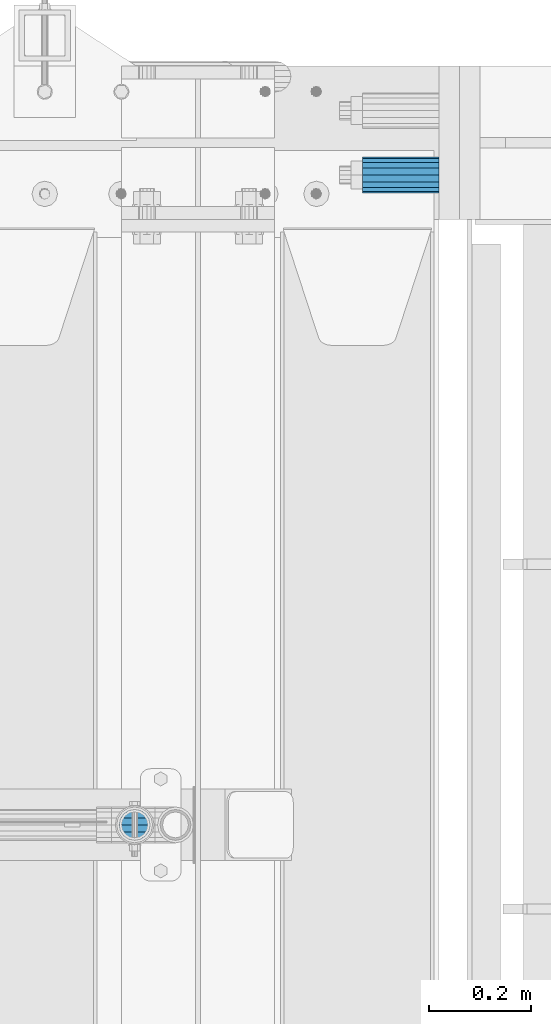
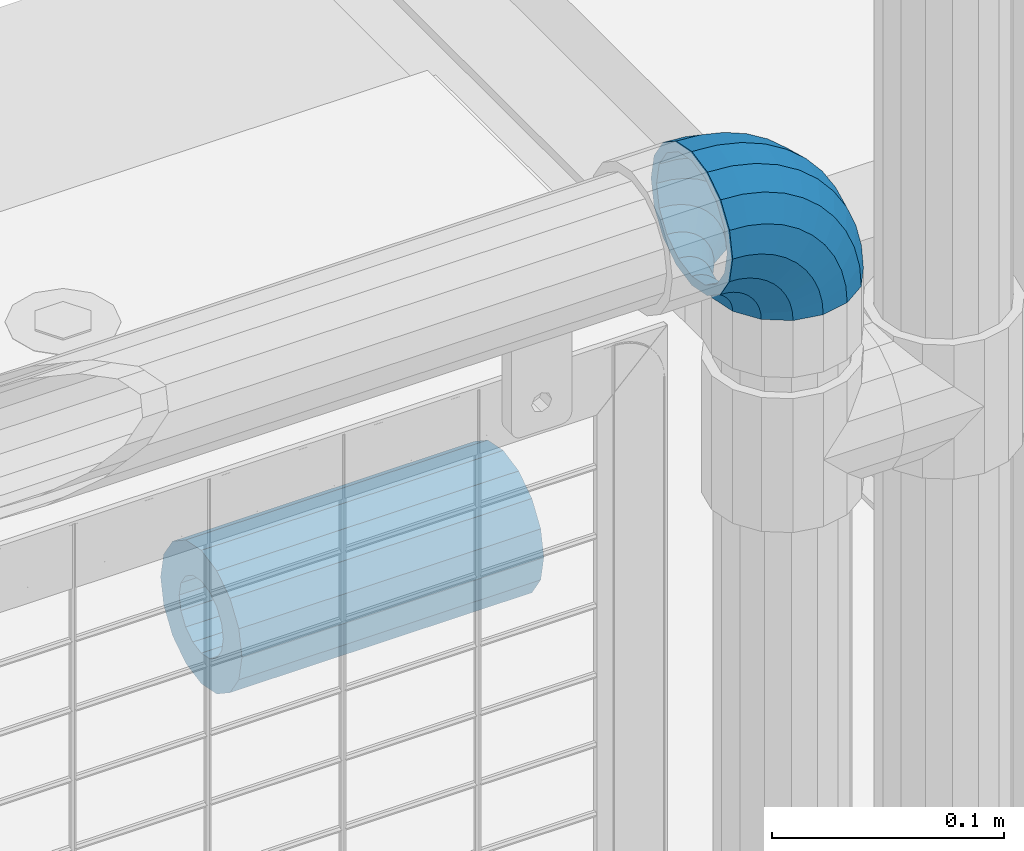
# One storey, part 170 of 242: 1 beam, 1 member.
"""IFC2X3 building model written with IfcOpenShell, lengths in millimetres."""

import ifcopenshell
import ifcopenshell.guid

model = None  # the IFC model being written
_history = None  # IfcOwnerHistory: only IFC2X3 demands one
_inside = {}  # id of a spatial element -> (the spatial element, [elements in it])
_under = {}  # id of a project, library or spatial element -> (it, [spatial elements below it])
_declared = {}  # id of a project -> (the project, [libraries it declares])
_typed = {}  # id of a type object -> (the type object, [elements of that type])
_made_of = {}  # id of a material, layer set ... -> (it, [elements and type objects made of it])


def new_model(schema):
    """Start an empty IFC model of exactly this schema.

    Asked for "IFC4X3", IfcOpenShell would pick the latest addendum, in which some entities
    have other attributes; the version numbers below select the first issue.
    IFC2X3 requires an IfcOwnerHistory on every rooted entity: one is made here for all.
    """
    global model, _history
    if schema == "IFC4X3":
        model = ifcopenshell.file(schema_version=(4, 3, 0, 0))
    else:
        model = ifcopenshell.file(schema=schema)
    _inside.clear()
    _under.clear()
    _declared.clear()
    _typed.clear()
    _made_of.clear()
    _history = None
    if model.schema == "IFC2X3":
        org = make("IfcOrganization", Name="unknown")
        user = make(
            "IfcPersonAndOrganization",
            ThePerson=make("IfcPerson", FamilyName="unknown"),
            TheOrganization=org,
        )
        app = make(
            "IfcApplication",
            ApplicationDeveloper=org,
            Version="unknown",
            ApplicationFullName="unknown",
            ApplicationIdentifier="unknown",
        )
        _history = make(
            "IfcOwnerHistory",
            OwningUser=user,
            OwningApplication=app,
            ChangeAction="ADDED",
            CreationDate=0,
        )
    return model


def make(cls, **values):
    """One entity of the class cls with the attributes given. An attribute that is None is left unset."""
    return model.create_entity(
        cls, **{name: value for name, value in values.items() if value is not None}
    )


def rooted(cls, **values):
    """An entity with a GlobalId (a new one), such as an element, a storey or a relation."""
    return make(cls, GlobalId=ifcopenshell.guid.new(), OwnerHistory=_history, **values)


def si_unit(unit_type, name, prefix=None):
    """IfcSIUnit, for example si_unit("LENGTHUNIT", "METRE", prefix="MILLI")."""
    return make("IfcSIUnit", UnitType=unit_type, Prefix=prefix, Name=name)


def assignment(units):
    """IfcUnitAssignment: the units of a project."""
    return None if units is None else make("IfcUnitAssignment", Units=units)


def point(xyz):
    """IfcCartesianPoint."""
    return None if xyz is None else make("IfcCartesianPoint", Coordinates=xyz)


def direction(xyz):
    """IfcDirection."""
    return None if xyz is None else make("IfcDirection", DirectionRatios=xyz)


def frame(location, z_axis=None, x_axis=None):
    """IfcAxis2Placement3D, a coordinate frame: its origin and axes. An axis left out is left unset."""
    return make(
        "IfcAxis2Placement3D",
        Location=point(location),
        Axis=direction(z_axis),
        RefDirection=direction(x_axis),
    )


def origin_with_axes():
    """The frame at (0, 0, 0) with the z axis (0, 0, 1) and the x axis (1, 0, 0) written out."""
    return frame((0.0, 0.0, 0.0), z_axis=(0.0, 0.0, 1.0), x_axis=(1.0, 0.0, 0.0))


def place(relative_to, where):
    """IfcLocalPlacement: puts the frame where relative to a parent placement (None: the world)."""
    return make(
        "IfcLocalPlacement", PlacementRelTo=relative_to, RelativePlacement=where
    )


def context(
    kind, dimensions, precision=None, world=None, true_north=None, identifier=None
):
    """IfcGeometricRepresentationContext, for example the 3D "Model" context."""
    return make(
        "IfcGeometricRepresentationContext",
        ContextIdentifier=identifier,
        ContextType=kind,
        CoordinateSpaceDimension=dimensions,
        Precision=precision,
        WorldCoordinateSystem=world,
        TrueNorth=true_north,
    )


def subcontext(parent, identifier, kind, view, scale=None):
    """IfcGeometricRepresentationSubContext, for example "Body" below "Model"."""
    return make(
        "IfcGeometricRepresentationSubContext",
        ContextIdentifier=identifier,
        ContextType=kind,
        ParentContext=parent,
        TargetScale=scale,
        TargetView=view,
    )


def project(units=None, contexts=None):
    """IfcProject with its units and contexts."""
    return rooted(
        "IfcProject",
        Name="project",
        RepresentationContexts=contexts,
        UnitsInContext=assignment(units),
    )


def spatial(cls, under=None, at=None, **own):
    """A site, building, storey or space (cls), placed at a placement, below another one or the project."""
    s = rooted(cls, ObjectPlacement=at, **own)
    if under is not None:
        _under.setdefault(under.id(), (under, []))[1].append(s)
    return s


def faces_of(points, faces, orient=None, outer=None):
    """IfcFace entities. A face is a list of loops; a loop is a list of indices into points, from 0.

    orient and outer hold one flag for each loop. By default every Orientation is true, the
    first loop of a face is its IfcFaceOuterBound and the others are IfcFaceBound.
    """
    made = []
    for i, loops in enumerate(faces):
        bounds = []
        for j, loop in enumerate(loops):
            is_outer = j == 0 if outer is None else outer[i][j]
            bounds.append(
                make(
                    "IfcFaceOuterBound" if is_outer else "IfcFaceBound",
                    Bound=make("IfcPolyLoop", Polygon=[points[k] for k in loop]),
                    Orientation=True if orient is None else orient[i][j],
                )
            )
        made.append(make("IfcFace", Bounds=bounds))
    return made


def faceted_brep(points, faces, orient=None, outer=None, voids=None):
    """IfcFacetedBrep: a solid bounded by flat faces; with voids (closed shells), ...WithVoids."""
    shared = [point(p) for p in points]
    hull = make("IfcClosedShell", CfsFaces=faces_of(shared, faces, orient, outer))
    if voids is None:
        return make("IfcFacetedBrep", Outer=hull)
    return make(
        "IfcFacetedBrepWithVoids",
        Outer=hull,
        Voids=[
            make(cls, CfsFaces=faces_of(shared, fs, o, b)) for cls, fs, o, b in voids
        ],
    )


def shape(context_of_items, identifier, shape_type, items):
    """IfcShapeRepresentation: the items that make up one representation, for example the "Body"."""
    return make(
        "IfcShapeRepresentation",
        ContextOfItems=context_of_items,
        RepresentationIdentifier=identifier,
        RepresentationType=shape_type,
        Items=items,
    )


def material(Name=None, Category=None):
    """IfcMaterial."""
    return make("IfcMaterial", Name=Name, Category=Category)


def made_of(thing, what):
    """Note that an element or type object is made of a material, layer set ...; save() writes the relation."""
    if what is not None:
        _made_of.setdefault(what.id(), (what, []))[1].append(thing)
    return thing


def type_object(cls, material=None, **own):
    """A type object (cls), such as IfcWallType, which elements share."""
    return made_of(rooted(cls, **own), material)


def element(
    cls,
    number,
    at=None,
    inside=None,
    cuts=None,
    type_object=None,
    material=None,
    context=None,
    identifier="Body",
    shape_type=None,
    held_by="IfcProductDefinitionShape",
    body=None,
    shapes=None,
    **own,
):
    """One element of the class cls, such as IfcWall. Its Tag is "e" and its number.

    at: its placement. inside: the storey or other place that contains it. cuts: it is an
    opening in that element (IfcRelVoidsElement). A single representation is given by context,
    identifier, shape_type and body (its items); several are given by shapes. held_by: the class
    of the entity that holds the representations. save() writes the other relations.
    """
    e = rooted(cls, Tag="e%d" % number, ObjectPlacement=at, **own)
    if body is not None:
        shapes = [shape(context, identifier, shape_type, body)]
    if shapes is not None:
        e.Representation = make(held_by, Representations=shapes)
    if inside is not None:
        _inside.setdefault(inside.id(), (inside, []))[1].append(e)
    if cuts is not None:
        rooted(
            "IfcRelVoidsElement", RelatingBuildingElement=cuts, RelatedOpeningElement=e
        )
    if type_object is not None:
        _typed.setdefault(type_object.id(), (type_object, []))[1].append(e)
    return made_of(e, material)


def aggregate(whole, parts):
    """IfcRelAggregates: a whole, such as a stair, and the parts it consists of."""
    return rooted("IfcRelAggregates", RelatingObject=whole, RelatedObjects=parts)


def save(model, path):
    """Write the relations noted so far, then the file.

    IfcRelAggregates (storeys below a building ...), IfcRelContainedInSpatialStructure (elements
    in a storey), IfcRelDefinesByType, IfcRelAssociatesMaterial and IfcRelDeclares: one each for
    every whole, place, type object, material and project.
    """
    for whole, parts in _under.values():
        aggregate(whole, parts)
    for where, things in _inside.values():
        rooted(
            "IfcRelContainedInSpatialStructure",
            RelatedElements=things,
            RelatingStructure=where,
        )
    for kind, things in _typed.values():
        rooted("IfcRelDefinesByType", RelatedObjects=things, RelatingType=kind)
    for what, things in _made_of.values():
        rooted("IfcRelAssociatesMaterial", RelatedObjects=things, RelatingMaterial=what)
    for by, libraries in _declared.values():
        rooted("IfcRelDeclares", RelatingContext=by, RelatedDefinitions=libraries)
    model.write(path)


model = new_model("IFC2X3")

# Units and contexts
model_context = context("Model", 3, precision=1e-05, world=origin_with_axes())
body_context = subcontext(model_context, "Body", "Model", "MODEL_VIEW")
ifc_project = project(units=[si_unit("LENGTHUNIT", "METRE", prefix="MILLI"), si_unit("AREAUNIT", "SQUARE_METRE"), si_unit("VOLUMEUNIT", "CUBIC_METRE"), si_unit("MASSUNIT", "GRAM", prefix="KILO"), si_unit("TIMEUNIT", "SECOND"), si_unit("PLANEANGLEUNIT", "RADIAN"), si_unit("SOLIDANGLEUNIT", "STERADIAN"), si_unit("THERMODYNAMICTEMPERATUREUNIT", "DEGREE_CELSIUS"), si_unit("LUMINOUSINTENSITYUNIT", "LUMEN")], contexts=[model_context])

# Site, building, storey
site_placement = place(None, origin_with_axes())
site = spatial("IfcSite", under=ifc_project, at=site_placement, CompositionType="ELEMENT")
building_placement = place(site_placement, origin_with_axes())
building = spatial("IfcBuilding", under=site, at=building_placement, Name="Standard", CompositionType="ELEMENT")
storey_placement = place(building_placement, origin_with_axes())
storey = spatial("IfcBuildingStorey", under=building, at=storey_placement, Name="Undefined", CompositionType="ELEMENT", Elevation=0.0)

# Member
ifc_material_1 = material(Name="Misc_Undefined")
member_type = type_object("IfcMemberType", PredefinedType="NOTDEFINED")
member_placement = place(storey_placement, frame((-22656.0, -19335.5, 924.85), z_axis=(0.707106781186547, 0.0, 0.707106781186548), x_axis=(-0.707106781186548, 0.0, 0.707106781186548)))
element("IfcMember", 1, at=member_placement, inside=storey, type_object=member_type, material=ifc_material_1, context=body_context, shape_type="Brep", body=[
    faceted_brep([(0.0, -35.1500000000015, 0.0), (9.51152146006643, -32.4743655677703, -9.51152146006643), (13.2759578763398, -32.4743655677703, -6.29638902527768), (5.36946880023243, -35.1500000000015, 4.58595959347804), (17.5749999999971, -24.8548033587067, -17.5749999999971), (19.978755663109, -24.8548033587067, -15.5219987155633), (22.9628441077002, -13.4513226476338, -22.9628441077002), (24.4574219585229, -13.4513226476338, -21.6863540323939), (24.8548033587067, 0.0, -24.8548033587067), (26.0301204183124, 0.0, -23.8509877588003), (22.9628441077002, 13.4513226476338, -22.9628441077002), (24.4574219585229, 13.4513226476338, -21.6863540323939), (17.5749999999971, 24.8548033587067, -17.5749999999971), (19.978755663109, 24.8548033587067, -15.5219987155633), (9.51152146006643, 32.4743655677703, -9.51152146006643), (13.2759578763398, 32.4743655677703, -6.29638902527768), (0.0, 35.1500000000015, 0.0), (5.36946880023243, 35.1500000000015, 4.58595959347804), (-9.51152146007371, 32.4743655677703, 9.51152146007371), (-2.53702027587133, 32.4743655677703, 15.4683082122338), (-17.5750000000007, 24.8548033587067, 17.5750000000007), (-9.23981806264783, 24.8548033587067, 24.6939179025212), (-22.9628441077039, 13.4513226476338, 22.9628441077039), (-13.718484358058, 13.4513226476338, 30.8582732193499), (-24.8548033587103, 0.0, 24.8548033587103), (-15.2911828178512, 0.0, 33.02290694576), (-22.9628441077039, -13.4513226476338, 22.9628441077039), (-13.718484358058, -13.4513226476338, 30.8582732193499), (-17.5750000000007, -24.8548033587067, 17.5750000000007), (-9.23981806264783, -24.8548033587067, 24.6939179025212), (-9.51152146007371, -32.4743655677703, 9.51152146007371), (-2.53702027587133, -32.4743655677703, 15.4683082122338), (0.0, -30.3499999999985, 0.0), (-8.2126508197216, -28.0397438117179, 8.2126508197216), (-1.45732902223972, -28.0397438117179, 13.9822406910389), (5.36946880023243, -30.3499999999985, 4.58595959347804), (-15.1749999999993, -21.46069080901, 15.1750000000029), (-7.24480876131565, -21.46069080901, 21.9480231689959), (-19.827092992, -11.614442172282, 19.827092992), (-11.1118790903529, -11.614442172282, 27.2705888550809), (-21.4606908090136, 0.0, 21.4606908090136), (-12.4698136068437, 0.0, 29.1396253727598), (-19.827092992, 11.614442172282, 19.827092992), (-11.1118790903529, 11.614442172282, 27.2705888550809), (-15.1749999999993, 21.46069080901, 15.1750000000029), (-7.24480876131565, 21.46069080901, 21.9480231689959), (-8.2126508197216, 28.0397438117179, 8.2126508197216), (-1.45732902223972, 28.0397438117179, 13.9822406910389), (0.0, 30.3499999999985, 0.0), (5.36946880023243, 30.3499999999985, 4.58595959347804), (8.21265081971796, 28.0397438117179, -8.21265081971796), (12.1962666227009, 28.0397438117179, -4.81032150407918), (15.1749999999956, 21.46069080901, -15.1749999999956), (17.9837463617769, 21.46069080901, -12.776103982038), (19.8270929919963, 11.614442172282, -19.8270929919963), (21.8508166908177, 11.614442172282, -18.0986696681193), (21.46069080901, 0.0, -21.46069080901), (23.2087512073085, 0.0, -19.9677061858001), (19.8270929919963, -11.614442172282, -19.8270929919963), (21.8508166908177, -11.614442172282, -18.0986696681193), (15.1749999999956, -21.46069080901, -15.1749999999956), (17.9837463617769, -21.46069080901, -12.776103982038), (8.21265081971796, -28.0397438117179, -8.21265081971796), (12.1962666227009, -28.0397438117179, -4.81032150407918), (17.4970053560683, -32.4743655677703, -3.70972780291959), (11.3902326651114, -35.1500000000015, 8.27548843508339), (22.6740772628618, -24.8548033587067, -13.870303514941), (26.1332861179508, -13.4513226476338, -20.6593831546816), (27.3479987309584, 0.0, -23.0433908901377), (26.1332861179508, 13.4513226476338, -20.6593831546816), (22.6740772628618, 24.8548033587067, -13.870303514941), (17.4970053560683, 32.4743655677703, -3.70972780291959), (11.3902326651114, 35.1500000000015, 8.27548843508339), (5.28345997415818, 32.4743655677703, 20.2607046730864), (0.106388067368243, 24.8548033587067, 30.4212803851133), (-3.35282078772798, 13.4513226476338, 37.2103600248483), (-4.56753340073192, 0.0, 39.5943677603045), (-3.35282078772798, -13.4513226476338, 37.2103600248483), (0.106388067368243, -24.8548033587067, 30.4212803851133), (5.28345997415818, -32.4743655677703, 20.2607046730864), (6.11738625912403, -28.0397438117179, 18.6240321853948), (11.3902326651114, -30.3499999999985, 8.27548843508339), (1.6472829199738, -21.46069080901, 27.3971039595017), (-1.3395446405375, -11.614442172282, 33.2590831078942), (-2.38837900198268, 0.0, 35.3175364441995), (-1.3395446405375, 11.614442172282, 33.2590831078942), (1.6472829199738, 21.46069080901, 27.3971039595017), (6.11738625912403, 28.0397438117179, 18.6240321853948), (11.3902326651114, 30.3499999999985, 8.27548843508339), (16.6630790711024, 28.0397438117179, -2.07305531522434), (21.1331824102526, 21.46069080901, -10.8461270893331), (24.1200099707639, 11.614442172282, -16.7081062377274), (25.1688443322091, 0.0, -18.7665595740364), (24.1200099707639, -11.614442172282, -16.7081062377274), (21.1331824102526, -21.46069080901, -10.8461270893331), (16.6630790711024, -28.0397438117179, -2.07305531522434), (22.070727701459, -32.4743655677703, -1.81522997692991), (17.9140404065183, -35.1500000000015, 10.9777380798896), (25.5945970362081, -24.8548033587067, -12.6605846156453), (27.9491712485069, -13.4513226476338, -19.9072189058916), (28.7759877587996, 0.0, -22.4518984678853), (27.9491712485069, 13.4513226476338, -19.9072189058916), (25.5945970362081, 24.8548033587067, -12.6605846156453), (22.070727701459, 32.4743655677703, -1.81522997692991), (17.9140404065183, 35.1500000000015, 10.9777380798896), (13.7573531115813, 32.4743655677703, 23.7707061367073), (10.2334837768321, 24.8548033587067, 34.6160607754227), (7.87890956453339, 13.4513226476338, 41.862695065669), (7.05209305424069, 0.0, 44.4073746276626), (7.87890956453339, -13.4513226476338, 41.862695065669), (10.2334837768321, -24.8548033587067, 34.6160607754227), (13.7573531115813, -32.4743655677703, 23.7707061367073), (14.3249803951003, -28.0397438117179, 22.0237289909674), (17.9140404065183, -30.3499999999985, 10.9777380798896), (11.2823222355109, -21.46069080901, 31.3880679179947), (9.24928305077992, -11.614442172282, 37.6451191472697), (8.53537462723762, 0.0, 39.8423033494473), (9.24928305077992, 11.614442172282, 37.6451191472697), (11.2823222355109, 21.46069080901, 31.3880679179947), (14.3249803951003, 28.0397438117179, 22.0237289909674), (17.9140404065183, 30.3499999999985, 10.9777380798896), (21.50310041794, 28.0397438117179, -0.0682528311899659), (24.5457585775293, 21.46069080901, -9.43259175821731), (26.5787977622604, 11.614442172282, -15.6896429874923), (27.2927061858027, 0.0, -17.8868271896699), (26.5787977622604, -11.614442172282, -15.6896429874923), (24.5457585775293, -21.46069080901, -9.43259175821731), (21.50310041794, -28.0397438117179, -0.0682528311899659), (26.8845046890456, -32.4743655677703, -0.659544371261291), (24.7802542265854, -35.1500000000015, 12.6261701733874), (28.6684020936846, -24.8548033587067, -11.9226293117918), (29.8603642316994, -13.4513226476338, -19.4483820661244), (30.2789256727447, 0.0, -22.0910749985305), (29.8603642316994, 13.4513226476338, -19.4483820661244), (28.6684020936846, 24.8548033587067, -11.9226293117918), (26.8845046890456, 32.4743655677703, -0.659544371261291), (24.7802542265854, 35.1500000000015, 12.6261701733874), (22.6760037641179, 32.4743655677703, 25.911884718038), (20.8921063594826, 24.8548033587067, 37.1749696585684), (19.7001442214641, 13.4513226476338, 44.7007224129011), (19.2815827804188, 0.0, 47.3434153453072), (19.7001442214641, -13.4513226476338, 44.7007224129011), (20.8921063594826, -24.8548033587067, 37.1749696585684), (22.6760037641179, -32.4743655677703, 25.911884718038), (22.963355178621, -28.0397438117179, 24.0976192894668), (24.7802542265854, -30.3499999999985, 12.6261701733874), (21.4230625404816, -21.46069080901, 33.8226442665673), (20.3938719035323, -11.614442172282, 40.3206982094944), (20.032468212612, 0.0, 42.6025113104497), (20.3938719035323, 11.614442172282, 40.3206982094944), (21.4230625404816, 21.46069080901, 33.8226442665673), (22.963355178621, 28.0397438117179, 24.0976192894668), (24.7802542265854, 30.3499999999985, 12.6261701733874), (26.5971532745461, 28.0397438117179, 1.15472105730987), (28.1374459126855, 21.46069080901, -8.5703039197906), (29.1666365496349, 11.614442172282, -15.0683578627177), (29.5280402405515, 0.0, -17.350170963673), (29.1666365496349, -11.614442172282, -15.0683578627177), (28.1374459126855, -21.46069080901, -8.5703039197906), (26.5971532745461, -28.0397438117179, 1.15472105730987), (31.8198051533909, -32.4743655677703, -0.271127801024704), (31.8198051533909, -35.1500000000015, 13.1801948466091), (31.8198051533946, -24.8548033587067, -11.6746085121031), (31.8198051533909, -13.4513226476338, -19.2941707211648), (31.8198051533909, 0.0, -21.9698051533924), (31.8198051533909, 13.4513226476338, -19.2941707211648), (31.8198051533946, 24.8548033587067, -11.6746085121031), (31.8198051533909, 32.4743655677703, -0.271127801024704), (31.8198051533909, 35.1500000000015, 13.1801948466091), (31.8198051533909, 32.4743655677703, 26.6315174942411), (31.8198051533909, 24.8548033587067, 38.0349982053158), (31.8198051533909, 13.4513226476338, 45.6545604143812), (31.8198051533946, 0.0, 48.3301948466051), (31.8198051533909, -13.4513226476338, 45.6545604143812), (31.8198051533909, -24.8548033587067, 38.0349982053158), (31.8198051533909, -32.4743655677703, 26.6315174942411), (31.8198051533909, -28.0397438117179, 24.7946370188874), (31.8198051533909, -30.3499999999985, 13.1801948466091), (31.8198051533946, -21.46069080901, 34.6408856556172), (31.8198051533946, -11.614442172282, 41.2199386583234), (31.8198051533909, 0.0, 43.5301948466076), (31.8198051533946, 11.614442172282, 41.2199386583234), (31.8198051533946, 21.46069080901, 34.6408856556172), (31.8198051533909, 28.0397438117179, 24.7946370188874), (31.8198051533909, 30.3499999999985, 13.1801948466091), (31.8198051533946, 28.0397438117179, 1.56575267432527), (31.8198051533909, 21.46069080901, -8.28049596240453), (31.8198051533946, 11.614442172282, -14.8595489651107), (31.8198051533909, 0.0, -17.1698051533913), (31.8198051533946, -11.614442172282, -14.8595489651107), (31.8198051533909, -21.46069080901, -8.28049596240453), (31.8198051533946, -28.0397438117179, 1.56575267432527), (36.7551056177363, -32.4743655677703, -0.659544371261291), (38.8593560802037, -35.1500000000015, 12.6261701733874), (34.9712082131009, -24.8548033587067, -11.9226293117899), (33.7792460750898, -13.4513226476338, -19.4483820661244), (33.3606846340372, 0.0, -22.0910749985305), (33.7792460750898, 13.4513226476338, -19.4483820661244), (34.9712082131009, 24.8548033587067, -11.9226293117899), (36.7551056177363, 32.4743655677703, -0.659544371261291), (38.8593560802037, 35.1500000000015, 12.6261701733874), (40.9636065426712, 32.4743655677703, 25.911884718038), (42.7475039473029, 24.8548033587067, 37.1749696585703), (43.9394660853177, 13.4513226476338, 44.7007224129011), (44.3580275263666, 0.0, 47.3434153453054), (43.9394660853177, -13.4513226476338, 44.7007224129011), (42.7475039473029, -24.8548033587067, 37.1749696585703), (40.9636065426712, -32.4743655677703, 25.911884718038), (40.6762551281645, -28.0397438117179, 24.097619289465), (38.8593560802037, -30.3499999999985, 12.6261701733874), (42.2165477663038, -21.46069080901, 33.8226442665655), (43.2457384032568, -11.614442172282, 40.3206982094944), (43.6071420941771, 0.0, 42.6025113104533), (43.2457384032568, 11.614442172282, 40.3206982094944), (42.2165477663038, 21.46069080901, 33.8226442665655), (40.6762551281645, 28.0397438117179, 24.097619289465), (38.8593560802037, 30.3499999999985, 12.6261701733874), (37.042457032243, 28.0397438117179, 1.15472105730987), (35.5021643941, 21.46069080901, -8.5703039197906), (34.4729737571543, 11.614442172282, -15.0683578627231), (34.1115700662303, 0.0, -17.350170963673), (34.4729737571543, -11.614442172282, -15.0683578627231), (35.5021643941, -21.46069080901, -8.5703039197906), (37.042457032243, -28.0397438117179, 1.15472105730987), (41.5688826053265, -32.4743655677703, -1.81522997693173), (45.7255699002671, -35.1500000000015, 10.9777380798896), (38.0450132705773, -24.8548033587067, -12.6605846156435), (35.6904390582749, -13.4513226476338, -19.9072189058897), (34.8636225479822, 0.0, -22.4518984678834), (35.6904390582749, 13.4513226476338, -19.9072189058897), (38.0450132705773, 24.8548033587067, -12.6605846156435), (41.5688826053265, 32.4743655677703, -1.81522997693173), (45.7255699002671, 35.1500000000015, 10.9777380798896), (49.8822571952041, 32.4743655677703, 23.7707061367091), (53.4061265299533, 24.8548033587067, 34.6160607754209), (55.7607007422557, 13.4513226476338, 41.8626950656671), (56.5875172525448, 0.0, 44.4073746276645), (55.7607007422557, -13.4513226476338, 41.8626950656671), (53.4061265299533, -24.8548033587067, 34.6160607754209), (49.8822571952041, -32.4743655677703, 23.7707061367091), (49.3146299116852, -28.0397438117179, 22.0237289909692), (45.7255699002671, -30.3499999999985, 10.9777380798896), (52.3572880712782, -21.46069080901, 31.3880679179947), (54.3903272560092, -11.614442172282, 37.6451191472679), (55.1042356795442, 0.0, 39.8423033494473), (54.3903272560092, 11.614442172282, 37.6451191472679), (52.3572880712782, 21.46069080901, 31.3880679179947), (49.3146299116852, 28.0397438117179, 22.0237289909692), (45.7255699002671, 30.3499999999985, 10.9777380798896), (42.1365098888455, 28.0397438117179, -0.0682528311917849), (39.0938517292525, 21.46069080901, -9.43259175821731), (37.0608125445215, 11.614442172282, -15.6896429874905), (36.3469041209864, 0.0, -17.8868271896699), (37.0608125445215, -11.614442172282, -15.6896429874905), (39.0938517292525, -21.46069080901, -9.43259175821731), (42.1365098888455, -28.0397438117179, -0.0682528311917849), (46.1426049507172, -32.4743655677703, -3.70972780292141), (52.2493776416704, -35.1500000000015, 8.27548843508339), (40.9655330439236, -24.8548033587067, -13.8703035149429), (37.5063241888347, -13.4513226476338, -20.6593831546797), (36.2916115758235, 0.0, -23.0433908901359), (37.5063241888347, 13.4513226476338, -20.6593831546797), (40.9655330439236, 24.8548033587067, -13.8703035149429), (46.1426049507172, 32.4743655677703, -3.70972780292141), (52.2493776416704, 35.1500000000015, 8.27548843508339), (58.3561503326309, 32.4743655677703, 20.26070467309), (63.5332222394209, 24.8548033587067, 30.4212803851133), (66.9924310945098, 13.4513226476338, 37.2103600248465), (68.2071437075174, 0.0, 39.5943677603027), (66.9924310945098, -13.4513226476338, 37.2103600248465), (63.5332222394209, -24.8548033587067, 30.4212803851133), (58.3561503326309, -32.4743655677703, 20.26070467309), (57.5222240476614, -28.0397438117179, 18.6240321853948), (52.2493776416704, -30.3499999999985, 8.27548843508339), (61.9923273868117, -21.46069080901, 27.3971039595035), (64.9791549473193, -11.614442172282, 33.259083107896), (66.0279893087682, 0.0, 35.3175364442013), (64.9791549473193, 11.614442172282, 33.259083107896), (61.9923273868117, 21.46069080901, 27.3971039595035), (57.5222240476614, 28.0397438117179, 18.6240321853948), (52.2493776416704, 30.3499999999985, 8.27548843508339), (46.9765312356831, 28.0397438117179, -2.07305531522616), (42.5064278965328, 21.46069080901, -10.8461270893349), (39.5196003360215, 11.614442172282, -16.7081062377292), (38.4707659745764, 0.0, -18.7665595740327), (39.5196003360215, -11.614442172282, -16.7081062377292), (42.5064278965328, -21.46069080901, -10.8461270893349), (46.9765312356831, -28.0397438117179, -2.07305531522616), (50.3636524304493, -32.4743655677703, -6.29638902527404), (58.2701415065567, -35.1500000000015, 4.58595959347986), (43.6608546436801, -24.8548033587067, -15.5219987155633), (39.1821883482626, -13.4513226476338, -21.686354032392), (37.609489888473, 0.0, -23.8509877587985), (39.1821883482626, 13.4513226476338, -21.686354032392), (43.6608546436801, 24.8548033587067, -15.5219987155633), (50.3636524304493, 32.4743655677703, -6.29638902527404), (58.2701415065567, 35.1500000000015, 4.58595959347986), (66.1766305826604, 32.4743655677703, 15.4683082122356), (72.8794283694297, 24.8548033587067, 24.6939179025212), (77.3580946648435, 13.4513226476338, 30.8582732193518), (78.9307931246331, 0.0, 33.02290694576), (77.3580946648435, -13.4513226476338, 30.8582732193518), (72.8794283694297, -24.8548033587067, 24.6939179025212), (66.1766305826604, -32.4743655677703, 15.4683082122356), (65.0969393290252, -28.0397438117179, 13.9822406910407), (58.2701415065567, -30.3499999999985, 4.58595959347986), (70.8844190681011, -21.46069080901, 21.9480231689959), (74.751489397142, -11.614442172282, 27.270588855079), (76.1094239136328, 0.0, 29.139625372758), (74.751489397142, 11.614442172282, 27.270588855079), (70.8844190681011, 21.46069080901, 21.9480231689959), (65.0969393290252, 28.0397438117179, 13.9822406910407), (58.2701415065567, 30.3499999999985, 4.58595959347986), (51.4433436840845, 28.0397438117179, -4.81032150407918), (45.655863945005, 21.46069080901, -12.7761039820361), (41.7887936159677, 11.614442172282, -18.0986696681175), (40.4308590994769, 0.0, -19.9677061858019), (41.7887936159677, -11.614442172282, -18.0986696681175), (45.655863945005, -21.46069080901, -12.7761039820361), (51.4433436840845, -28.0397438117179, -4.81032150407918), (54.1280888467154, -32.4743655677703, -9.51152146006643), (63.6396103067855, -35.1500000000015, 3.63797880709171e-12), (46.0646103067847, -24.8548033587067, -17.5749999999971), (40.6767661990853, -13.4513226476338, -22.9628441077002), (38.7848069480788, 0.0, -24.8548033587049), (40.6767661990853, 13.4513226476338, -22.9628441077002), (46.0646103067847, 24.8548033587067, -17.5749999999971), (54.1280888467154, 32.4743655677703, -9.51152146006643), (63.6396103067855, 35.1500000000015, 3.63797880709171e-12), (73.1511317668555, 32.4743655677703, 9.51152146007189), (81.2146103067862, 24.8548033587067, 17.5750000000025), (86.6024544144893, 13.4513226476338, 22.9628441077057), (88.4944136654922, 0.0, 24.8548033587103), (86.6024544144893, -13.4513226476338, 22.9628441077057), (81.2146103067862, -24.8548033587067, 17.5750000000025), (73.1511317668555, -32.4743655677703, 9.51152146007189), (71.8522611265034, -28.0397438117179, 8.2126508197216), (63.6396103067855, -30.3499999999985, 3.63797880709171e-12), (78.8146103067847, -21.46069080901, 15.1750000000029), (83.4667032987854, -11.614442172282, 19.8270929920018), (85.1003011157991, 0.0, 21.4606908090154), (83.4667032987854, 11.614442172282, 19.8270929920018), (78.8146103067847, 21.46069080901, 15.1750000000029), (71.8522611265034, 28.0397438117179, 8.2126508197216), (63.6396103067855, 30.3499999999985, 3.63797880709171e-12), (55.4269594870675, 28.0397438117179, -8.21265081971615), (48.4646103067862, 21.46069080901, -15.1749999999975), (43.8125173147855, 11.614442172282, -19.8270929919963), (42.1789194977755, 0.0, -21.4606908090082), (43.8125173147855, -11.614442172282, -19.8270929919963), (48.4646103067862, -21.46069080901, -15.1749999999975), (55.4269594870675, -28.0397438117179, -8.21265081971615)], [[[0, 1, 2, 3]], [[1, 4, 5, 2]], [[4, 6, 7, 5]], [[6, 8, 9, 7]], [[8, 10, 11, 9]], [[10, 12, 13, 11]], [[12, 14, 15, 13]], [[14, 16, 17, 15]], [[16, 18, 19, 17]], [[18, 20, 21, 19]], [[20, 22, 23, 21]], [[22, 24, 25, 23]], [[24, 26, 27, 25]], [[26, 28, 29, 27]], [[28, 30, 31, 29]], [[30, 0, 3, 31]], [[32, 33, 34, 35]], [[33, 36, 37, 34]], [[36, 38, 39, 37]], [[38, 40, 41, 39]], [[40, 42, 43, 41]], [[42, 44, 45, 43]], [[44, 46, 47, 45]], [[46, 48, 49, 47]], [[48, 50, 51, 49]], [[50, 52, 53, 51]], [[52, 54, 55, 53]], [[54, 56, 57, 55]], [[56, 58, 59, 57]], [[58, 60, 61, 59]], [[60, 62, 63, 61]], [[62, 32, 35, 63]], [[30, 28, 26, 24, 22, 20, 18, 16, 14, 12, 10, 8, 6, 4, 1, 0], [62, 60, 58, 56, 54, 52, 50, 48, 46, 44, 42, 40, 38, 36, 33, 32]], [[3, 2, 64, 65]], [[2, 5, 66, 64]], [[5, 7, 67, 66]], [[7, 9, 68, 67]], [[9, 11, 69, 68]], [[11, 13, 70, 69]], [[13, 15, 71, 70]], [[15, 17, 72, 71]], [[17, 19, 73, 72]], [[19, 21, 74, 73]], [[21, 23, 75, 74]], [[23, 25, 76, 75]], [[25, 27, 77, 76]], [[27, 29, 78, 77]], [[29, 31, 79, 78]], [[31, 3, 65, 79]], [[35, 34, 80, 81]], [[34, 37, 82, 80]], [[37, 39, 83, 82]], [[39, 41, 84, 83]], [[41, 43, 85, 84]], [[43, 45, 86, 85]], [[45, 47, 87, 86]], [[47, 49, 88, 87]], [[49, 51, 89, 88]], [[51, 53, 90, 89]], [[53, 55, 91, 90]], [[55, 57, 92, 91]], [[57, 59, 93, 92]], [[59, 61, 94, 93]], [[61, 63, 95, 94]], [[63, 35, 81, 95]], [[65, 64, 96, 97]], [[64, 66, 98, 96]], [[66, 67, 99, 98]], [[67, 68, 100, 99]], [[68, 69, 101, 100]], [[69, 70, 102, 101]], [[70, 71, 103, 102]], [[71, 72, 104, 103]], [[72, 73, 105, 104]], [[73, 74, 106, 105]], [[74, 75, 107, 106]], [[75, 76, 108, 107]], [[76, 77, 109, 108]], [[77, 78, 110, 109]], [[78, 79, 111, 110]], [[79, 65, 97, 111]], [[81, 80, 112, 113]], [[80, 82, 114, 112]], [[82, 83, 115, 114]], [[83, 84, 116, 115]], [[84, 85, 117, 116]], [[85, 86, 118, 117]], [[86, 87, 119, 118]], [[87, 88, 120, 119]], [[88, 89, 121, 120]], [[89, 90, 122, 121]], [[90, 91, 123, 122]], [[91, 92, 124, 123]], [[92, 93, 125, 124]], [[93, 94, 126, 125]], [[94, 95, 127, 126]], [[95, 81, 113, 127]], [[97, 96, 128, 129]], [[96, 98, 130, 128]], [[98, 99, 131, 130]], [[99, 100, 132, 131]], [[100, 101, 133, 132]], [[101, 102, 134, 133]], [[102, 103, 135, 134]], [[103, 104, 136, 135]], [[104, 105, 137, 136]], [[105, 106, 138, 137]], [[106, 107, 139, 138]], [[107, 108, 140, 139]], [[108, 109, 141, 140]], [[109, 110, 142, 141]], [[110, 111, 143, 142]], [[111, 97, 129, 143]], [[113, 112, 144, 145]], [[112, 114, 146, 144]], [[114, 115, 147, 146]], [[115, 116, 148, 147]], [[116, 117, 149, 148]], [[117, 118, 150, 149]], [[118, 119, 151, 150]], [[119, 120, 152, 151]], [[120, 121, 153, 152]], [[121, 122, 154, 153]], [[122, 123, 155, 154]], [[123, 124, 156, 155]], [[124, 125, 157, 156]], [[125, 126, 158, 157]], [[126, 127, 159, 158]], [[127, 113, 145, 159]], [[129, 128, 160, 161]], [[128, 130, 162, 160]], [[130, 131, 163, 162]], [[131, 132, 164, 163]], [[132, 133, 165, 164]], [[133, 134, 166, 165]], [[134, 135, 167, 166]], [[135, 136, 168, 167]], [[136, 137, 169, 168]], [[137, 138, 170, 169]], [[138, 139, 171, 170]], [[139, 140, 172, 171]], [[140, 141, 173, 172]], [[141, 142, 174, 173]], [[142, 143, 175, 174]], [[143, 129, 161, 175]], [[145, 144, 176, 177]], [[144, 146, 178, 176]], [[146, 147, 179, 178]], [[147, 148, 180, 179]], [[148, 149, 181, 180]], [[149, 150, 182, 181]], [[150, 151, 183, 182]], [[151, 152, 184, 183]], [[152, 153, 185, 184]], [[153, 154, 186, 185]], [[154, 155, 187, 186]], [[155, 156, 188, 187]], [[156, 157, 189, 188]], [[157, 158, 190, 189]], [[158, 159, 191, 190]], [[159, 145, 177, 191]], [[161, 160, 192, 193]], [[160, 162, 194, 192]], [[162, 163, 195, 194]], [[163, 164, 196, 195]], [[164, 165, 197, 196]], [[165, 166, 198, 197]], [[166, 167, 199, 198]], [[167, 168, 200, 199]], [[168, 169, 201, 200]], [[169, 170, 202, 201]], [[170, 171, 203, 202]], [[171, 172, 204, 203]], [[172, 173, 205, 204]], [[173, 174, 206, 205]], [[174, 175, 207, 206]], [[175, 161, 193, 207]], [[177, 176, 208, 209]], [[176, 178, 210, 208]], [[178, 179, 211, 210]], [[179, 180, 212, 211]], [[180, 181, 213, 212]], [[181, 182, 214, 213]], [[182, 183, 215, 214]], [[183, 184, 216, 215]], [[184, 185, 217, 216]], [[185, 186, 218, 217]], [[186, 187, 219, 218]], [[187, 188, 220, 219]], [[188, 189, 221, 220]], [[189, 190, 222, 221]], [[190, 191, 223, 222]], [[191, 177, 209, 223]], [[193, 192, 224, 225]], [[192, 194, 226, 224]], [[194, 195, 227, 226]], [[195, 196, 228, 227]], [[196, 197, 229, 228]], [[197, 198, 230, 229]], [[198, 199, 231, 230]], [[199, 200, 232, 231]], [[200, 201, 233, 232]], [[201, 202, 234, 233]], [[202, 203, 235, 234]], [[203, 204, 236, 235]], [[204, 205, 237, 236]], [[205, 206, 238, 237]], [[206, 207, 239, 238]], [[207, 193, 225, 239]], [[209, 208, 240, 241]], [[208, 210, 242, 240]], [[210, 211, 243, 242]], [[211, 212, 244, 243]], [[212, 213, 245, 244]], [[213, 214, 246, 245]], [[214, 215, 247, 246]], [[215, 216, 248, 247]], [[216, 217, 249, 248]], [[217, 218, 250, 249]], [[218, 219, 251, 250]], [[219, 220, 252, 251]], [[220, 221, 253, 252]], [[221, 222, 254, 253]], [[222, 223, 255, 254]], [[223, 209, 241, 255]], [[225, 224, 256, 257]], [[224, 226, 258, 256]], [[226, 227, 259, 258]], [[227, 228, 260, 259]], [[228, 229, 261, 260]], [[229, 230, 262, 261]], [[230, 231, 263, 262]], [[231, 232, 264, 263]], [[232, 233, 265, 264]], [[233, 234, 266, 265]], [[234, 235, 267, 266]], [[235, 236, 268, 267]], [[236, 237, 269, 268]], [[237, 238, 270, 269]], [[238, 239, 271, 270]], [[239, 225, 257, 271]], [[241, 240, 272, 273]], [[240, 242, 274, 272]], [[242, 243, 275, 274]], [[243, 244, 276, 275]], [[244, 245, 277, 276]], [[245, 246, 278, 277]], [[246, 247, 279, 278]], [[247, 248, 280, 279]], [[248, 249, 281, 280]], [[249, 250, 282, 281]], [[250, 251, 283, 282]], [[251, 252, 284, 283]], [[252, 253, 285, 284]], [[253, 254, 286, 285]], [[254, 255, 287, 286]], [[255, 241, 273, 287]], [[257, 256, 288, 289]], [[256, 258, 290, 288]], [[258, 259, 291, 290]], [[259, 260, 292, 291]], [[260, 261, 293, 292]], [[261, 262, 294, 293]], [[262, 263, 295, 294]], [[263, 264, 296, 295]], [[264, 265, 297, 296]], [[265, 266, 298, 297]], [[266, 267, 299, 298]], [[267, 268, 300, 299]], [[268, 269, 301, 300]], [[269, 270, 302, 301]], [[270, 271, 303, 302]], [[271, 257, 289, 303]], [[273, 272, 304, 305]], [[272, 274, 306, 304]], [[274, 275, 307, 306]], [[275, 276, 308, 307]], [[276, 277, 309, 308]], [[277, 278, 310, 309]], [[278, 279, 311, 310]], [[279, 280, 312, 311]], [[280, 281, 313, 312]], [[281, 282, 314, 313]], [[282, 283, 315, 314]], [[283, 284, 316, 315]], [[284, 285, 317, 316]], [[285, 286, 318, 317]], [[286, 287, 319, 318]], [[287, 273, 305, 319]], [[289, 288, 320, 321]], [[288, 290, 322, 320]], [[290, 291, 323, 322]], [[291, 292, 324, 323]], [[292, 293, 325, 324]], [[293, 294, 326, 325]], [[294, 295, 327, 326]], [[295, 296, 328, 327]], [[296, 297, 329, 328]], [[297, 298, 330, 329]], [[298, 299, 331, 330]], [[299, 300, 332, 331]], [[300, 301, 333, 332]], [[301, 302, 334, 333]], [[302, 303, 335, 334]], [[303, 289, 321, 335]], [[305, 304, 336, 337]], [[304, 306, 338, 336]], [[306, 307, 339, 338]], [[307, 308, 340, 339]], [[308, 309, 341, 340]], [[309, 310, 342, 341]], [[310, 311, 343, 342]], [[311, 312, 344, 343]], [[312, 313, 345, 344]], [[313, 314, 346, 345]], [[314, 315, 347, 346]], [[315, 316, 348, 347]], [[316, 317, 349, 348]], [[317, 318, 350, 349]], [[318, 319, 351, 350]], [[319, 305, 337, 351]], [[322, 323, 324, 325, 326, 327, 328, 329, 330, 331, 332, 333, 334, 335, 321, 320], [338, 339, 340, 341, 342, 343, 344, 345, 346, 347, 348, 349, 350, 351, 337, 336]]]),
])

# Beam
ifc_material_2 = material()
beam_type = type_object("IfcBeamType", PredefinedType="NOTDEFINED")
beam_placement = place(storey_placement, frame((-22210.0, -18063.0, -183.0), z_axis=(0.0, 0.0, 1.0), x_axis=(1.0, 0.0, 0.0)))
element("IfcBeam", 2, at=beam_placement, inside=storey, type_object=beam_type, material=ifc_material_2, context=body_context, shape_type="Brep", body=[
    faceted_brep([(1.33248249767348e-07, -19.0000000004493, -6.26823748461902e-09), (0.0, -17.5537111177146, 7.27098521493673), (150.0, -17.5537111177146, 7.27098521493673), (150.0, -19.0, 0.0), (0.0, -13.4350288425449, 13.4350288425444), (150.0, -13.4350288425449, 13.4350288425444), (0.0, -7.27098521493826, 17.5537111177144), (150.0, -7.27098521493826, 17.5537111177144), (-6.29370333626866e-09, -4.49290382675827e-10, 18.9999999937318), (150.0, 0.0, 19.0), (0.0, 7.27098521493826, 17.5537111177144), (150.0, 7.27098521493826, 17.5537111177144), (0.0, 13.4350288425449, 13.4350288425444), (150.0, 13.4350288425449, 13.4350288425444), (0.0, 17.5537111177146, 7.2709852149367), (150.0, 17.5537111177146, 7.2709852149367), (-1.31243723444641e-07, 18.9999999995507, -6.26823748461902e-09), (150.0, 19.0, 0.0), (0.0, 17.5537111177146, -7.2709852149367), (150.0, 17.5537111177146, -7.2709852149367), (0.0, 13.4350288425449, -13.4350288425444), (150.0, 13.4350288425449, -13.4350288425444), (0.0, 7.27098521493826, -17.5537111177144), (150.0, 7.27098521493826, -17.5537111177144), (8.2982296589762e-09, -4.49290382675827e-10, -19.0000000062719), (150.0, 0.0, -19.0), (0.0, -7.27098521493826, -17.5537111177144), (150.0, -7.27098521493826, -17.5537111177144), (0.0, -13.4350288425449, -13.4350288425444), (150.0, -13.4350288425449, -13.4350288425444), (0.0, -17.5537111177146, -7.2709852149367), (150.0, -17.5537111177146, -7.2709852149367), (-3.63797880709171e-12, -35.0, 0.0), (-3.63797880709171e-12, -32.335783637895, -13.3939201327812), (150.0, -32.3357836378964, -13.3939201327782), (150.0, -35.0, 0.0), (0.0, -24.7487373415292, -24.7487373415315), (150.0, -24.7487373415279, -24.7487373415292), (0.0, -13.3939201327782, -32.3357836378964), (150.0, -13.3939201327776, -32.335783637895), (0.0, 0.0, -35.0000000000036), (150.0, 0.0, -35.0), (0.0, 13.3939201327782, -32.3357836378964), (150.0, 13.3939201327776, -32.335783637895), (0.0, 24.7487373415292, -24.7487373415315), (150.0, 24.7487373415279, -24.7487373415292), (-3.63797880709171e-12, 32.335783637895, -13.3939201327812), (150.0, 32.3357836378964, -13.3939201327781), (-3.63797880709171e-12, 35.0, 0.0), (150.0, 35.0, 0.0), (-7.27595761418343e-12, 32.335783637895, 13.3939201327739), (150.0, 32.3357836378964, 13.3939201327781), (-7.27595761418343e-12, 24.7487373415292, 24.7487373415242), (150.0, 24.7487373415279, 24.7487373415292), (-7.27595761418343e-12, 13.3939201327781, 32.3357836378891), (150.0, 13.3939201327776, 32.335783637895), (-1.09139364212751e-11, 0.0, 34.9999999999964), (150.0, 0.0, 35.0), (-7.27595761418343e-12, -13.3939201327781, 32.3357836378891), (150.0, -13.3939201327776, 32.335783637895), (-7.27595761418343e-12, -24.7487373415292, 24.7487373415242), (150.0, -24.7487373415279, 24.7487373415292), (-7.27595761418343e-12, -32.335783637895, 13.3939201327739), (150.0, -32.3357836378964, 13.3939201327781)], [[[0, 1, 2, 3]], [[1, 4, 5, 2]], [[4, 6, 7, 5]], [[6, 8, 9, 7]], [[8, 10, 11, 9]], [[10, 12, 13, 11]], [[12, 14, 15, 13]], [[14, 16, 17, 15]], [[16, 18, 19, 17]], [[18, 20, 21, 19]], [[20, 22, 23, 21]], [[22, 24, 25, 23]], [[24, 26, 27, 25]], [[26, 28, 29, 27]], [[28, 30, 31, 29]], [[30, 0, 3, 31]], [[32, 33, 34, 35]], [[33, 36, 37, 34]], [[36, 38, 39, 37]], [[38, 40, 41, 39]], [[40, 42, 43, 41]], [[42, 44, 45, 43]], [[44, 46, 47, 45]], [[46, 48, 49, 47]], [[48, 50, 51, 49]], [[50, 52, 53, 51]], [[52, 54, 55, 53]], [[54, 56, 57, 55]], [[56, 58, 59, 57]], [[58, 60, 61, 59]], [[60, 62, 63, 61]], [[62, 32, 35, 63]], [[37, 39, 41, 43, 45, 47, 49, 51, 53, 55, 57, 59, 61, 63, 35, 34], [5, 7, 9, 11, 13, 15, 17, 19, 21, 23, 25, 27, 29, 31, 3, 2]], [[62, 60, 58, 56, 54, 52, 50, 48, 46, 44, 42, 40, 38, 36, 33, 32], [30, 28, 26, 24, 22, 20, 18, 16, 14, 12, 10, 8, 6, 4, 1, 0]]]),
])

save(model, "model.ifc")
